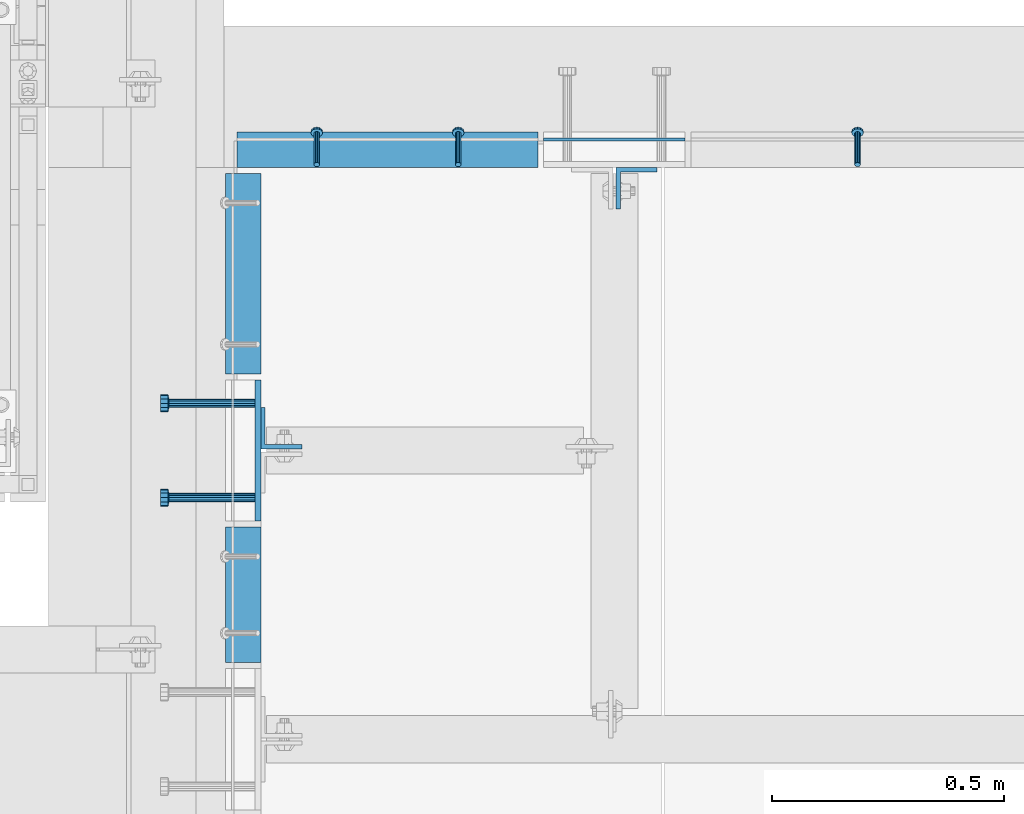
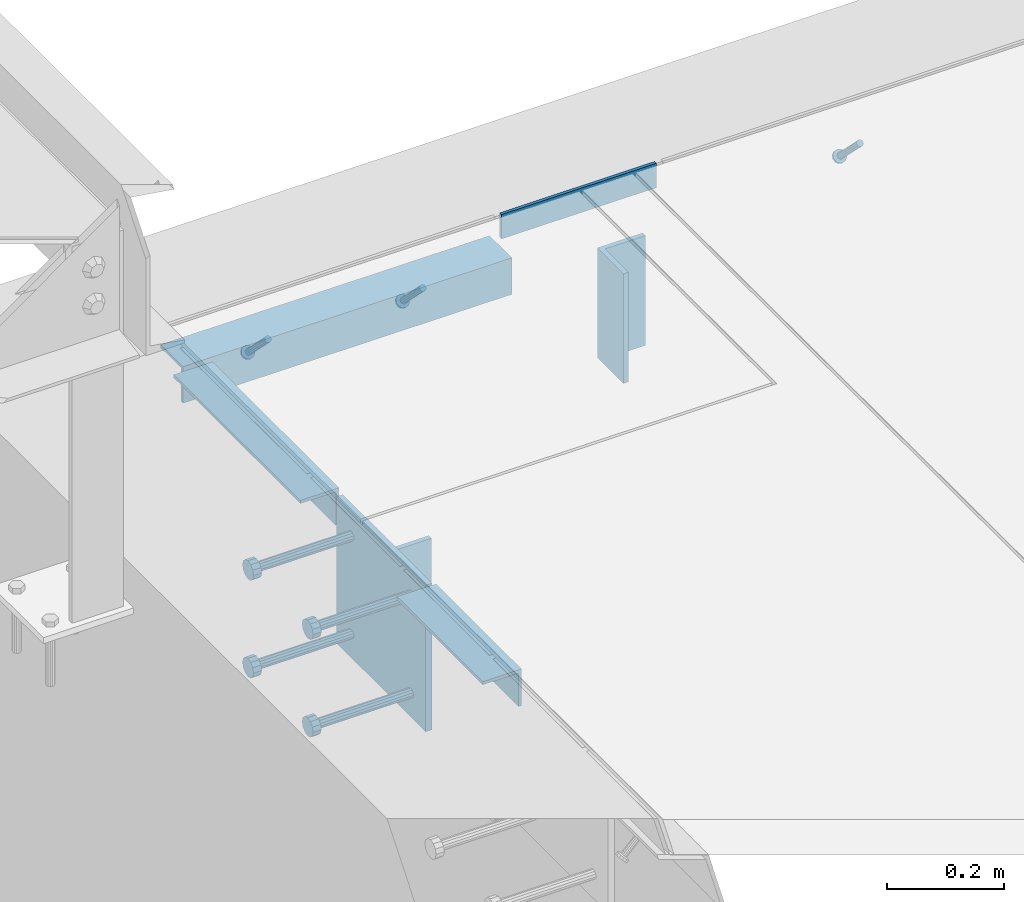
# One storey, part 2078 of 3843: 11 beams, 3 members, 8 elements without a shape of their own.
"""IFC2X3 building model written with IfcOpenShell, lengths in millimetres."""

from ifc_helpers import new_model, si_unit, frame, origin_with_axes, place, context, subcontext, project, spatial, faceted_brep, material, type_object, element, aggregate, save


model = new_model("IFC2X3")

# Units and contexts
model_context = context("Model", 3, precision=1e-05, world=origin_with_axes())
body_context = subcontext(model_context, "Body", "Model", "MODEL_VIEW")
ifc_project = project(units=[si_unit("LENGTHUNIT", "METRE", prefix="MILLI"), si_unit("AREAUNIT", "SQUARE_METRE"), si_unit("VOLUMEUNIT", "CUBIC_METRE"), si_unit("MASSUNIT", "GRAM", prefix="KILO"), si_unit("TIMEUNIT", "SECOND"), si_unit("PLANEANGLEUNIT", "RADIAN"), si_unit("SOLIDANGLEUNIT", "STERADIAN"), si_unit("THERMODYNAMICTEMPERATUREUNIT", "DEGREE_CELSIUS"), si_unit("LUMINOUSINTENSITYUNIT", "LUMEN")], contexts=[model_context])

# Site, building, storey
site_placement = place(None, origin_with_axes())
site = spatial("IfcSite", under=ifc_project, at=site_placement, CompositionType="ELEMENT")
building_placement = place(site_placement, origin_with_axes())
building = spatial("IfcBuilding", under=site, at=building_placement, Name="Undefined", CompositionType="ELEMENT")
storey_placement = place(building_placement, origin_with_axes())
storey = spatial("IfcBuildingStorey", under=building, at=storey_placement, Name="Undefined", CompositionType="ELEMENT", Elevation=0.0)

# Assembly, beam
assembly_1_placement = place(storey_placement, origin_with_axes())
assembly_1 = element("IfcElementAssembly", 1, at=assembly_1_placement, inside=storey, Name="EMBED PLATE", AssemblyPlace="NOTDEFINED", PredefinedType="RIGID_FRAME")
ifc_material_1 = material(Name="STEEL/A36")
beam_type_1 = type_object("IfcBeamType", PredefinedType="NOTDEFINED")
beam_1_placement = place(assembly_1_placement, frame((56749.95, 18751.55, 30454.6), z_axis=(0.0, 0.0, 1.0), x_axis=(1.0, 0.0, 0.0)))
beam_1 = element("IfcBeam", 2, at=beam_1_placement, type_object=beam_type_1, material=ifc_material_1, Name="PLATE", context=body_context, shape_type="Brep", body=[
    faceted_brep([(0.0, 3.17499999999927, -25.4000000000015), (0.0, 3.17499999999927, 25.4000000000015), (304.800000000003, 3.17500000000291, 25.4000000000015), (304.800000000003, 3.17500000000291, -25.4000000000015), (0.0, -3.17499999999927, 25.4000000000015), (304.800000000003, -3.17500000000291, 25.4000000000015), (0.0, -3.17499999999927, -25.4000000000015), (304.800000000003, -3.17500000000291, -25.4000000000015)], [[[0, 1, 2, 3]], [[1, 4, 5, 2]], [[4, 6, 7, 5]], [[6, 0, 3, 7]], [[5, 7, 3, 2]], [[6, 4, 1, 0]]]),
])
aggregate(assembly_1, [beam_1])

# Assembly, member
assembly_2_placement = place(storey_placement, origin_with_axes())
assembly_2 = element("IfcElementAssembly", 3, at=assembly_2_placement, inside=storey, Name="ANGLE", AssemblyPlace="NOTDEFINED", PredefinedType="RIGID_FRAME")
ifc_material_2 = material(Name="STEEL/A108")
member_type = type_object("IfcMemberType", PredefinedType="NOTDEFINED")
member_1_placement = place(assembly_2_placement, frame((57426.2248493546, 18697.5750781257, 30422.8500030518), z_axis=(-1.0, 0.0, 0.0), x_axis=(5.70000238222118e-08, 0.707106781186546, -0.707106781186546)))
member_1 = element("IfcMember", 4, at=member_1_placement, type_object=member_type, material=ifc_material_2, Name="HEADED STUD ANCHOR", context=body_context, shape_type="Brep", body=[
    faceted_brep([(7.27595761418343e-12, -3.18000006675175, 5.5), (0.0, -5.49999999998363, 3.1800000667572), (94.4879985803855, -5.50000000011278, 3.1800000667572), (94.4879985803782, -3.18000006687362, 5.5), (0.0, -6.3499999046162, 0.0), (94.4879985803855, -6.34999990474535, 0.0), (0.0, -5.49999999998363, -3.1800000667572), (94.4879985803855, -5.50000000011278, -3.1800000667572), (7.27595761418343e-12, -3.18000006675175, -5.5), (94.4879985803782, -3.18000006687362, -5.5), (7.27595761418343e-12, -1.81898940354586e-12, -6.34999990463257), (94.4879985803782, -1.20053300634027e-10, -6.34999990463257), (0.0, 3.18000006675175, -5.5), (94.4879985803709, 3.18000006663351, -5.5), (7.27595761418343e-12, 5.49999999998363, -3.1800000667572), (94.4879985803709, 5.49999999987267, -3.1800000667572), (7.27595761418343e-12, 6.3499999046162, 0.0), (94.4879985803673, 6.34999990450706, 0.0), (7.27595761418343e-12, 5.49999999998363, 3.1800000667572), (94.4879985803709, 5.49999999987267, 3.1800000667572), (0.0, 3.18000006675175, 5.5), (94.4879985803709, 3.18000006663351, 5.5), (7.27595761418343e-12, -1.81898940354586e-12, 6.34999990463257), (94.4879985803782, -1.20053300634027e-10, 6.34999990463257), (96.5199985498621, -10.9899997712273, 6.34999990463257), (96.5199985498548, -6.34000015270249, 10.9899997711182), (96.5199985498621, -12.6999998093743, 0.0), (96.5199985498621, -10.9899997712273, -6.34999990463257), (96.5199985498548, -6.34000015270249, -10.9899997711182), (96.5199985498475, -1.21872290037572e-10, -12.6899995803833), (96.5199985498402, 6.34000015245874, -10.9899997711182), (96.519998549833, 10.9899997709817, -6.34999990463257), (96.519998549833, 12.6999998091305, 0.0), (96.519998549833, 10.9899997709817, 6.34999990463257), (96.5199985498402, 6.34000015245874, 10.9899997711182), (96.5199985498475, -1.21872290037572e-10, 12.6899995803833), (101.599998473539, -10.9899997712328, 6.34999990463257), (101.599998473532, -6.34000015270976, 10.9899997711182), (101.599998473539, -12.6999998093797, 0.0), (101.599998473539, -10.9899997712328, -6.34999990463257), (101.599998473532, -6.34000015270976, -10.9899997711182), (101.599998473524, -1.29148247651756e-10, -12.6899995803833), (101.599998473517, 6.34000015245329, -10.9899997711182), (101.59999847351, 10.9899997709763, -6.34999990463257), (101.599998473503, 12.6999998091196, 0.0), (101.59999847351, 10.9899997709763, 6.34999990463257), (101.599998473517, 6.34000015245329, 10.9899997711182), (101.599998473524, -1.29148247651756e-10, 12.6899995803833)], [[[0, 1, 2, 3]], [[1, 4, 5, 2]], [[4, 6, 7, 5]], [[6, 8, 9, 7]], [[8, 10, 11, 9]], [[10, 12, 13, 11]], [[12, 14, 15, 13]], [[14, 16, 17, 15]], [[16, 18, 19, 17]], [[18, 20, 21, 19]], [[20, 22, 23, 21]], [[22, 0, 3, 23]], [[22, 20, 18, 16, 14, 12, 10, 8, 6, 4, 1, 0]], [[3, 2, 24, 25]], [[2, 5, 26, 24]], [[5, 7, 27, 26]], [[7, 9, 28, 27]], [[9, 11, 29, 28]], [[11, 13, 30, 29]], [[13, 15, 31, 30]], [[15, 17, 32, 31]], [[17, 19, 33, 32]], [[19, 21, 34, 33]], [[21, 23, 35, 34]], [[23, 3, 25, 35]], [[25, 24, 36, 37]], [[24, 26, 38, 36]], [[26, 27, 39, 38]], [[27, 28, 40, 39]], [[28, 29, 41, 40]], [[29, 30, 42, 41]], [[30, 31, 43, 42]], [[31, 32, 44, 43]], [[32, 33, 45, 44]], [[33, 34, 46, 45]], [[34, 35, 47, 46]], [[35, 25, 37, 47]], [[38, 39, 40, 41, 42, 43, 44, 45, 46, 47, 37, 36]]]),
])
aggregate(assembly_2, [member_1])

# Assembly, members
assembly_3_placement = place(storey_placement, origin_with_axes())
assembly_3 = element("IfcElementAssembly", 5, at=assembly_3_placement, inside=storey, Name="ANGLE", AssemblyPlace="NOTDEFINED", PredefinedType="RIGID_FRAME")
member_2_placement = place(assembly_3_placement, frame((56565.799910662, 18697.574900916, 30422.8500030518), z_axis=(-1.0, 0.0, 0.0), x_axis=(5.70000238222118e-08, 0.707106781186546, -0.707106781186546)))
member_2 = element("IfcMember", 6, at=member_2_placement, type_object=member_type, material=ifc_material_2, Name="HEADED STUD ANCHOR", context=body_context, shape_type="Brep", body=[
    faceted_brep([(7.27595761418343e-12, -3.18000006675175, 5.5), (0.0, -5.49999999998363, 3.1800000667572), (94.4879985803855, -5.50000000011278, 3.1800000667572), (94.4879985803782, -3.18000006687362, 5.5), (0.0, -6.3499999046162, 0.0), (94.4879985803855, -6.34999990474535, 0.0), (0.0, -5.49999999998363, -3.1800000667572), (94.4879985803855, -5.50000000011278, -3.1800000667572), (7.27595761418343e-12, -3.18000006675175, -5.5), (94.4879985803782, -3.18000006687362, -5.5), (7.27595761418343e-12, -1.81898940354586e-12, -6.34999990463257), (94.4879985803782, -1.20053300634027e-10, -6.34999990463257), (0.0, 3.18000006675175, -5.5), (94.4879985803709, 3.18000006663351, -5.5), (7.27595761418343e-12, 5.49999999998363, -3.1800000667572), (94.4879985803709, 5.49999999987267, -3.1800000667572), (7.27595761418343e-12, 6.3499999046162, 0.0), (94.4879985803673, 6.34999990450706, 0.0), (7.27595761418343e-12, 5.49999999998363, 3.1800000667572), (94.4879985803709, 5.49999999987267, 3.1800000667572), (0.0, 3.18000006675175, 5.5), (94.4879985803709, 3.18000006663351, 5.5), (7.27595761418343e-12, -1.81898940354586e-12, 6.34999990463257), (94.4879985803782, -1.20053300634027e-10, 6.34999990463257), (96.5199985498621, -10.9899997712273, 6.34999990463257), (96.5199985498548, -6.34000015270249, 10.9899997711182), (96.5199985498621, -12.6999998093743, 0.0), (96.5199985498621, -10.9899997712273, -6.34999990463257), (96.5199985498548, -6.34000015270249, -10.9899997711182), (96.5199985498475, -1.21872290037572e-10, -12.6899995803833), (96.5199985498402, 6.34000015245874, -10.9899997711182), (96.519998549833, 10.9899997709817, -6.34999990463257), (96.519998549833, 12.6999998091305, 0.0), (96.519998549833, 10.9899997709817, 6.34999990463257), (96.5199985498402, 6.34000015245874, 10.9899997711182), (96.5199985498475, -1.21872290037572e-10, 12.6899995803833), (101.599998473539, -10.9899997712328, 6.34999990463257), (101.599998473532, -6.34000015270976, 10.9899997711182), (101.599998473539, -12.6999998093797, 0.0), (101.599998473539, -10.9899997712328, -6.34999990463257), (101.599998473532, -6.34000015270976, -10.9899997711182), (101.599998473524, -1.29148247651756e-10, -12.6899995803833), (101.599998473517, 6.34000015245329, -10.9899997711182), (101.59999847351, 10.9899997709763, -6.34999990463257), (101.599998473503, 12.6999998091196, 0.0), (101.59999847351, 10.9899997709763, 6.34999990463257), (101.599998473517, 6.34000015245329, 10.9899997711182), (101.599998473524, -1.29148247651756e-10, 12.6899995803833)], [[[0, 1, 2, 3]], [[1, 4, 5, 2]], [[4, 6, 7, 5]], [[6, 8, 9, 7]], [[8, 10, 11, 9]], [[10, 12, 13, 11]], [[12, 14, 15, 13]], [[14, 16, 17, 15]], [[16, 18, 19, 17]], [[18, 20, 21, 19]], [[20, 22, 23, 21]], [[22, 0, 3, 23]], [[22, 20, 18, 16, 14, 12, 10, 8, 6, 4, 1, 0]], [[3, 2, 24, 25]], [[2, 5, 26, 24]], [[5, 7, 27, 26]], [[7, 9, 28, 27]], [[9, 11, 29, 28]], [[11, 13, 30, 29]], [[13, 15, 31, 30]], [[15, 17, 32, 31]], [[17, 19, 33, 32]], [[19, 21, 34, 33]], [[21, 23, 35, 34]], [[23, 3, 25, 35]], [[25, 24, 36, 37]], [[24, 26, 38, 36]], [[26, 27, 39, 38]], [[27, 28, 40, 39]], [[28, 29, 41, 40]], [[29, 30, 42, 41]], [[30, 31, 43, 42]], [[31, 32, 44, 43]], [[32, 33, 45, 44]], [[33, 34, 46, 45]], [[34, 35, 47, 46]], [[35, 25, 37, 47]], [[38, 39, 40, 41, 42, 43, 44, 45, 46, 47, 37, 36]]]),
])
member_3_placement = place(assembly_3_placement, frame((56260.999910662, 18697.574900916, 30422.8500030518), z_axis=(-1.0, 0.0, 0.0), x_axis=(5.70000238222118e-08, 0.707106781186546, -0.707106781186546)))
member_3 = element("IfcMember", 7, at=member_3_placement, type_object=member_type, material=ifc_material_2, Name="HEADED STUD ANCHOR", context=body_context, shape_type="Brep", body=[
    faceted_brep([(7.27595761418343e-12, -3.18000006675175, 5.5), (0.0, -5.49999999998363, 3.1800000667572), (94.4879985803855, -5.50000000011278, 3.1800000667572), (94.4879985803782, -3.18000006687362, 5.5), (0.0, -6.3499999046162, 0.0), (94.4879985803855, -6.34999990474535, 0.0), (0.0, -5.49999999998363, -3.1800000667572), (94.4879985803855, -5.50000000011278, -3.1800000667572), (7.27595761418343e-12, -3.18000006675175, -5.5), (94.4879985803782, -3.18000006687362, -5.5), (7.27595761418343e-12, -1.81898940354586e-12, -6.34999990463257), (94.4879985803782, -1.20053300634027e-10, -6.34999990463257), (0.0, 3.18000006675175, -5.5), (94.4879985803709, 3.18000006663351, -5.5), (7.27595761418343e-12, 5.49999999998363, -3.1800000667572), (94.4879985803709, 5.49999999987267, -3.1800000667572), (7.27595761418343e-12, 6.3499999046162, 0.0), (94.4879985803673, 6.34999990450706, 0.0), (7.27595761418343e-12, 5.49999999998363, 3.1800000667572), (94.4879985803709, 5.49999999987267, 3.1800000667572), (0.0, 3.18000006675175, 5.5), (94.4879985803709, 3.18000006663351, 5.5), (7.27595761418343e-12, -1.81898940354586e-12, 6.34999990463257), (94.4879985803782, -1.20053300634027e-10, 6.34999990463257), (96.5199985498621, -10.9899997712273, 6.34999990463257), (96.5199985498548, -6.34000015270249, 10.9899997711182), (96.5199985498621, -12.6999998093743, 0.0), (96.5199985498621, -10.9899997712273, -6.34999990463257), (96.5199985498548, -6.34000015270249, -10.9899997711182), (96.5199985498475, -1.21872290037572e-10, -12.6899995803833), (96.5199985498402, 6.34000015245874, -10.9899997711182), (96.519998549833, 10.9899997709817, -6.34999990463257), (96.519998549833, 12.6999998091305, 0.0), (96.519998549833, 10.9899997709817, 6.34999990463257), (96.5199985498402, 6.34000015245874, 10.9899997711182), (96.5199985498475, -1.21872290037572e-10, 12.6899995803833), (101.599998473539, -10.9899997712328, 6.34999990463257), (101.599998473532, -6.34000015270976, 10.9899997711182), (101.599998473539, -12.6999998093797, 0.0), (101.599998473539, -10.9899997712328, -6.34999990463257), (101.599998473532, -6.34000015270976, -10.9899997711182), (101.599998473524, -1.29148247651756e-10, -12.6899995803833), (101.599998473517, 6.34000015245329, -10.9899997711182), (101.59999847351, 10.9899997709763, -6.34999990463257), (101.599998473503, 12.6999998091196, 0.0), (101.59999847351, 10.9899997709763, 6.34999990463257), (101.599998473517, 6.34000015245329, 10.9899997711182), (101.599998473524, -1.29148247651756e-10, 12.6899995803833)], [[[0, 1, 2, 3]], [[1, 4, 5, 2]], [[4, 6, 7, 5]], [[6, 8, 9, 7]], [[8, 10, 11, 9]], [[10, 12, 13, 11]], [[12, 14, 15, 13]], [[14, 16, 17, 15]], [[16, 18, 19, 17]], [[18, 20, 21, 19]], [[20, 22, 23, 21]], [[22, 0, 3, 23]], [[22, 20, 18, 16, 14, 12, 10, 8, 6, 4, 1, 0]], [[3, 2, 24, 25]], [[2, 5, 26, 24]], [[5, 7, 27, 26]], [[7, 9, 28, 27]], [[9, 11, 29, 28]], [[11, 13, 30, 29]], [[13, 15, 31, 30]], [[15, 17, 32, 31]], [[17, 19, 33, 32]], [[19, 21, 34, 33]], [[21, 23, 35, 34]], [[23, 3, 25, 35]], [[25, 24, 36, 37]], [[24, 26, 38, 36]], [[26, 27, 39, 38]], [[27, 28, 40, 39]], [[28, 29, 41, 40]], [[29, 30, 42, 41]], [[30, 31, 43, 42]], [[31, 32, 44, 43]], [[32, 33, 45, 44]], [[33, 34, 46, 45]], [[34, 35, 47, 46]], [[35, 25, 37, 47]], [[38, 39, 40, 41, 42, 43, 44, 45, 46, 47, 37, 36]]]),
])

# Assembly, beam
assembly_4_placement = place(storey_placement, origin_with_axes())
assembly_4 = element("IfcElementAssembly", 8, at=assembly_4_placement, inside=storey, Name="EMBED PLATE", AssemblyPlace="NOTDEFINED", PredefinedType="RIGID_FRAME")
beam_type_2 = type_object("IfcBeamType", PredefinedType="NOTDEFINED")
beam_2_placement = place(assembly_4_placement, frame((56134.0000030518, 18081.625, 30422.85), z_axis=(0.0, 1.0, 0.0), x_axis=(0.0, 0.0, -1.0)))
beam_2 = element("IfcBeam", 9, at=beam_2_placement, type_object=beam_type_2, material=ifc_material_1, Name="EMBED PLATE", context=body_context, shape_type="Brep", body=[
    faceted_brep([(-1.0550138540566e-10, 6.34999999999854, -152.400000000664), (1.0550138540566e-10, 6.34999999999854, 152.400000000656), (304.799999999999, 6.34999999999854, 152.400000000001), (304.799999999999, 6.34999999999854, -152.400000000001), (1.0550138540566e-10, -6.34999999999854, 152.400000000656), (304.799999999999, -6.34999999999854, 152.400000000001), (-1.0550138540566e-10, -6.34999999999854, -152.400000000664), (304.799999999999, -6.34999999999854, -152.400000000001)], [[[0, 1, 2, 3]], [[1, 4, 5, 2]], [[4, 6, 7, 5]], [[6, 0, 3, 7]], [[5, 7, 3, 2]], [[6, 4, 1, 0]]]),
])

assembly_5_placement = place(storey_placement, origin_with_axes())
assembly_5 = element("IfcElementAssembly", 10, at=assembly_5_placement, inside=storey, Name="ANGLE", AssemblyPlace="NOTDEFINED", PredefinedType="RIGID_FRAME")
beam_type_3 = type_object("IfcBeamType", Name="L3X3X1/4", PredefinedType="NOTDEFINED")
beam_3_placement = place(assembly_5_placement, frame((56102.2500000941, 17624.4250731787, 30391.1000045777), z_axis=(0.0, 0.0, -1.0), x_axis=(0.0, 1.0, 0.0)))
beam_3 = element("IfcBeam", 11, at=beam_3_placement, type_object=beam_type_3, material=ifc_material_1, Name="ANGLE", ObjectType="L3X3X1/4", context=body_context, shape_type="Brep", body=[
    faceted_brep([(0.0, 38.0999999999985, -38.0999999999985), (0.0, 38.0999999999985, 38.0999999999985), (292.099926759005, 38.0999999991764, 38.0999999999985), (292.099926759005, 38.0999999991764, -38.0999999999985), (0.0, 31.75, 38.0999999999985), (292.099926759009, 31.7499999991778, 38.0999999999985), (0.0, 31.75, -31.75), (292.099926759009, 31.7499999991778, -31.75), (0.0, -38.0999999999985, -31.75), (292.099926759067, -38.1000000008207, -31.75), (0.0, -38.0999999999985, -38.0999999999985), (292.099926759067, -38.1000000008207, -38.0999999999985)], [[[0, 1, 2, 3]], [[1, 4, 5, 2]], [[4, 6, 7, 5]], [[6, 8, 9, 7]], [[8, 10, 11, 9]], [[10, 0, 3, 11]], [[5, 7, 9, 11, 3, 2]], [[10, 8, 6, 4, 1, 0]]]),
])
aggregate(assembly_5, [beam_3])

assembly_6_placement = place(storey_placement, origin_with_axes())
assembly_6 = element("IfcElementAssembly", 12, at=assembly_6_placement, inside=storey, Name="ANGLE", AssemblyPlace="NOTDEFINED", PredefinedType="RIGID_FRAME")
beam_4_placement = place(assembly_6_placement, frame((56102.2500000941, 18246.7250002667, 30391.1000045777), z_axis=(0.0, 0.0, -1.0), x_axis=(0.0, 1.0, 0.0)))
beam_4 = element("IfcBeam", 13, at=beam_4_placement, type_object=beam_type_3, material=ifc_material_1, Name="ANGLE", ObjectType="L3X3X1/4", context=body_context, shape_type="Brep", body=[
    faceted_brep([(0.0, 38.0999999999985, -38.0999999999985), (0.0, 38.0999999999985, 38.0999999999985), (431.800000000025, 38.0999999997803, 38.0999999999985), (431.800000000025, 38.0999999997803, -38.0999999999985), (0.0, 31.75, 38.0999999999985), (431.800000000021, 31.7499999997817, 38.0999999999985), (0.0, 31.75, -31.75), (431.800000000021, 31.7499999997817, -31.75), (0.0, -38.0999999999985, -31.75), (431.799999999981, -38.1000000002241, -31.75), (0.0, -38.0999999999985, -38.0999999999985), (431.799999999981, -38.1000000002241, -38.0999999999985)], [[[0, 1, 2, 3]], [[1, 4, 5, 2]], [[4, 6, 7, 5]], [[6, 8, 9, 7]], [[8, 10, 11, 9]], [[10, 0, 3, 11]], [[5, 7, 9, 11, 3, 2]], [[10, 8, 6, 4, 1, 0]]]),
])
aggregate(assembly_6, [beam_4])

# Beam
beam_5_placement = place(assembly_3_placement, frame((56089.5498712958, 18729.324900916, 30391.1000030518), z_axis=(0.0, 0.0, -1.0), x_axis=(1.0, 0.0, 0.0)))
beam_5 = element("IfcBeam", 14, at=beam_5_placement, type_object=beam_type_3, material=ifc_material_1, Name="ANGLE", ObjectType="L3X3X1/4", context=body_context, shape_type="Brep", body=[
    faceted_brep([(0.0, 38.0999999999985, -38.0999999999985), (0.0, 38.0999999999985, 38.0999999999985), (647.700078732363, 38.0999999999985, 38.0999999999985), (647.700078732363, 38.0999999999985, -38.0999999999985), (0.0, 31.75, 38.0999999999985), (647.700078732363, 31.75, 38.0999999999985), (0.0, 31.75, -31.75), (647.700078732363, 31.75, -31.75), (0.0, -38.0999999999985, -31.75), (647.700078732363, -38.0999999999985, -31.75), (0.0, -38.0999999999985, -38.0999999999985), (647.700078732363, -38.0999999999985, -38.0999999999985)], [[[0, 1, 2, 3]], [[1, 4, 5, 2]], [[4, 6, 7, 5]], [[6, 8, 9, 7]], [[8, 10, 11, 9]], [[10, 0, 3, 11]], [[5, 7, 9, 11, 3, 2]], [[10, 8, 6, 4, 1, 0]]]),
])

aggregate(assembly_3, [member_2, member_3, beam_5])

# Assembly, beam
assembly_7_placement = place(storey_placement, origin_with_axes())
assembly_7 = element("IfcElementAssembly", 15, at=assembly_7_placement, inside=storey, Name="BEAM", AssemblyPlace="NOTDEFINED", PredefinedType="RIGID_FRAME")
beam_type_4 = type_object("IfcBeamType", Name="L3-1/2X3-1/2X3/8", PredefinedType="NOTDEFINED")
beam_6_placement = place(assembly_7_placement, frame((56184.8000030518, 18129.25, 30391.1), z_axis=(0.0, 1.0, 0.0), x_axis=(0.0, 0.0, -1.0)))
beam_6 = element("IfcBeam", 16, at=beam_6_placement, type_object=beam_type_4, material=ifc_material_1, Name="ANGLE", ObjectType="L3-1/2X3-1/2X3/8", context=body_context, shape_type="Brep", body=[
    faceted_brep([(-3.63797880709171e-12, 44.4499999999971, -44.4500000000007), (-3.63797880709171e-12, 44.4499999999971, 44.4500000000007), (228.600000000006, 44.4499999999971, 44.4500000000007), (228.600000000006, 44.4499999999971, -44.4500000000007), (0.0, 34.9250000000029, 44.4500000000007), (228.600000000006, 34.9250000000029, 44.4500000000007), (0.0, 34.9250000000029, -34.9250000000029), (228.600000000006, 34.9250000000029, -34.9249999999993), (0.0, -44.4499999999971, -34.9249999999993), (228.600000000006, -44.4499999999971, -34.9249999999993), (3.63797880709171e-12, -44.4499999999971, -44.4500000000007), (228.600000000006, -44.4499999999971, -44.4500000000007)], [[[0, 1, 2, 3]], [[1, 4, 5, 2]], [[4, 6, 7, 5]], [[6, 8, 9, 7]], [[8, 10, 11, 9]], [[10, 0, 3, 11]], [[5, 7, 9, 11, 3, 2]], [[10, 8, 6, 4, 1, 0]]]),
])
aggregate(assembly_7, [beam_6])

assembly_8_placement = place(storey_placement, origin_with_axes())
assembly_8 = element("IfcElementAssembly", 17, at=assembly_8_placement, inside=storey, Name="BEAM", AssemblyPlace="NOTDEFINED", PredefinedType="RIGID_FRAME")
beam_7_placement = place(assembly_8_placement, frame((56949.975, 18646.775, 30391.1), z_axis=(1.0, 0.0, 0.0), x_axis=(0.0, 0.0, -1.0)))
beam_7 = element("IfcBeam", 18, at=beam_7_placement, type_object=beam_type_4, material=ifc_material_1, Name="ANGLE", ObjectType="L3-1/2X3-1/2X3/8", context=body_context, shape_type="Brep", body=[
    faceted_brep([(-3.63797880709171e-12, 44.4499999999971, -44.4500000000007), (-3.63797880709171e-12, 44.4499999999971, 44.4500000000007), (228.600000000006, 44.4499999999971, 44.4500000000007), (228.600000000006, 44.4499999999971, -44.4500000000007), (0.0, 34.9250000000029, 44.4500000000007), (228.600000000006, 34.9250000000029, 44.4500000000007), (0.0, 34.9250000000029, -34.9250000000029), (228.600000000006, 34.9250000000029, -34.9249999999993), (0.0, -44.4499999999971, -34.9249999999993), (228.600000000006, -44.4499999999971, -34.9249999999993), (3.63797880709171e-12, -44.4499999999971, -44.4500000000007), (228.600000000006, -44.4499999999971, -44.4500000000007)], [[[0, 1, 2, 3]], [[1, 4, 5, 2]], [[4, 6, 7, 5]], [[6, 8, 9, 7]], [[8, 10, 11, 9]], [[10, 0, 3, 11]], [[5, 7, 9, 11, 3, 2]], [[10, 8, 6, 4, 1, 0]]]),
])
aggregate(assembly_8, [beam_7])

# Beam
beam_type_5 = type_object("IfcBeamType", PredefinedType="NOTDEFINED")
beam_8_placement = place(assembly_4_placement, frame((56127.6500030518, 17980.025, 30372.05), z_axis=(0.0, -1.0, 0.0), x_axis=(-1.0, 0.0, 0.0)))
beam_8 = element("IfcBeam", 19, at=beam_8_placement, type_object=beam_type_5, material=ifc_material_2, Name="HEADED STUD ANCHOR", context=body_context, shape_type="Brep", body=[
    faceted_brep([(0.0, -9.52000045776367, 0.0), (0.0, -8.25, -4.76000022888184), (184.912000000004, -8.25, -4.76000022888184), (184.912000000004, -9.52000045776367, 0.0), (0.0, -4.76000022888184, -8.25), (184.912000000004, -4.76000022888184, -8.25), (0.0, 0.0, -9.52000045776367), (184.912000000004, 0.0, -9.52000045776367), (0.0, 4.76000022888184, -8.25), (184.912000000004, 4.76000022888184, -8.25), (0.0, 8.25, -4.76000022888184), (184.912000000004, 8.25, -4.76000022888184), (0.0, 9.52000045776367, 0.0), (184.912000000004, 9.52000045776367, 0.0), (0.0, 8.25, 4.76000022888184), (184.912000000004, 8.25, 4.76000022888184), (0.0, 4.76000022888184, 8.25), (184.912000000004, 4.76000022888184, 8.25), (0.0, 0.0, 9.52000045776367), (184.912000000004, 0.0, 9.52000045776367), (0.0, -4.76000022888184, 8.25), (184.912000000004, -4.76000022888184, 8.25), (0.0, -8.25, 4.76000022888184), (184.912000000004, -8.25, 4.76000022888184), (186.944000000003, -16.5, -9.52000045776367), (186.944000000003, -19.0499992370605, 0.0), (186.944000000003, -9.52000045776367, -16.5), (186.944000000003, 0.0, -19.0499992370605), (186.944000000003, 9.52000045776367, -16.5), (186.944000000003, 16.5, -9.52000045776367), (186.944000000003, 19.0499992370605, 0.0), (186.944000000003, 16.5, 9.52000045776367), (186.944000000003, 9.52000045776367, 16.5), (186.944000000003, 0.0, 19.0499992370605), (186.944000000003, -9.52000045776367, 16.5), (186.944000000003, -16.5, 9.52000045776367), (203.199999999997, -16.5, -9.52000045776367), (203.199999999997, -19.0499992370605, 0.0), (203.199999999997, -9.52000045776367, -16.5), (203.199999999997, 0.0, -19.0499992370605), (203.199999999997, 9.52000045776367, -16.5), (203.199999999997, 16.5, -9.52000045776367), (203.199999999997, 19.0499992370605, 0.0), (203.199999999997, 16.5, 9.52000045776367), (203.199999999997, 9.52000045776367, 16.5), (203.199999999997, 0.0, 19.0499992370605), (203.199999999997, -9.52000045776367, 16.5), (203.199999999997, -16.5, 9.52000045776367)], [[[0, 1, 2, 3]], [[1, 4, 5, 2]], [[4, 6, 7, 5]], [[6, 8, 9, 7]], [[8, 10, 11, 9]], [[10, 12, 13, 11]], [[12, 14, 15, 13]], [[14, 16, 17, 15]], [[16, 18, 19, 17]], [[18, 20, 21, 19]], [[20, 22, 23, 21]], [[22, 0, 3, 23]], [[22, 20, 18, 16, 14, 12, 10, 8, 6, 4, 1, 0]], [[3, 2, 24, 25]], [[2, 5, 26, 24]], [[5, 7, 27, 26]], [[7, 9, 28, 27]], [[9, 11, 29, 28]], [[11, 13, 30, 29]], [[13, 15, 31, 30]], [[15, 17, 32, 31]], [[17, 19, 33, 32]], [[19, 21, 34, 33]], [[21, 23, 35, 34]], [[23, 3, 25, 35]], [[25, 24, 36, 37]], [[24, 26, 38, 36]], [[26, 27, 39, 38]], [[27, 28, 40, 39]], [[28, 29, 41, 40]], [[29, 30, 42, 41]], [[30, 31, 43, 42]], [[31, 32, 44, 43]], [[32, 33, 45, 44]], [[33, 34, 46, 45]], [[34, 35, 47, 46]], [[35, 25, 37, 47]], [[38, 39, 40, 41, 42, 43, 44, 45, 46, 47, 37, 36]]]),
])

beam_9_placement = place(assembly_4_placement, frame((56127.6500030518, 17980.025, 30168.85), z_axis=(0.0, -1.0, 0.0), x_axis=(-1.0, 0.0, 0.0)))
beam_9 = element("IfcBeam", 20, at=beam_9_placement, type_object=beam_type_5, material=ifc_material_2, Name="HEADED STUD ANCHOR", context=body_context, shape_type="Brep", body=[
    faceted_brep([(0.0, -9.52000045776367, 0.0), (0.0, -8.25, -4.76000022888184), (184.912000000004, -8.25, -4.76000022888184), (184.912000000004, -9.52000045776367, 0.0), (0.0, -4.76000022888184, -8.25), (184.912000000004, -4.76000022888184, -8.25), (0.0, 0.0, -9.52000045776367), (184.912000000004, 0.0, -9.52000045776367), (0.0, 4.76000022888184, -8.25), (184.912000000004, 4.76000022888184, -8.25), (0.0, 8.25, -4.76000022888184), (184.912000000004, 8.25, -4.76000022888184), (0.0, 9.52000045776367, 0.0), (184.912000000004, 9.52000045776367, 0.0), (0.0, 8.25, 4.76000022888184), (184.912000000004, 8.25, 4.76000022888184), (0.0, 4.76000022888184, 8.25), (184.912000000004, 4.76000022888184, 8.25), (0.0, 0.0, 9.52000045776367), (184.912000000004, 0.0, 9.52000045776367), (0.0, -4.76000022888184, 8.25), (184.912000000004, -4.76000022888184, 8.25), (0.0, -8.25, 4.76000022888184), (184.912000000004, -8.25, 4.76000022888184), (186.944000000003, -16.5, -9.52000045776367), (186.944000000003, -19.0499992370605, 0.0), (186.944000000003, -9.52000045776367, -16.5), (186.944000000003, 0.0, -19.0499992370605), (186.944000000003, 9.52000045776367, -16.5), (186.944000000003, 16.5, -9.52000045776367), (186.944000000003, 19.0499992370605, 0.0), (186.944000000003, 16.5, 9.52000045776367), (186.944000000003, 9.52000045776367, 16.5), (186.944000000003, 0.0, 19.0499992370605), (186.944000000003, -9.52000045776367, 16.5), (186.944000000003, -16.5, 9.52000045776367), (203.199999999997, -16.5, -9.52000045776367), (203.199999999997, -19.0499992370605, 0.0), (203.199999999997, -9.52000045776367, -16.5), (203.199999999997, 0.0, -19.0499992370605), (203.199999999997, 9.52000045776367, -16.5), (203.199999999997, 16.5, -9.52000045776367), (203.199999999997, 19.0499992370605, 0.0), (203.199999999997, 16.5, 9.52000045776367), (203.199999999997, 9.52000045776367, 16.5), (203.199999999997, 0.0, 19.0499992370605), (203.199999999997, -9.52000045776367, 16.5), (203.199999999997, -16.5, 9.52000045776367)], [[[0, 1, 2, 3]], [[1, 4, 5, 2]], [[4, 6, 7, 5]], [[6, 8, 9, 7]], [[8, 10, 11, 9]], [[10, 12, 13, 11]], [[12, 14, 15, 13]], [[14, 16, 17, 15]], [[16, 18, 19, 17]], [[18, 20, 21, 19]], [[20, 22, 23, 21]], [[22, 0, 3, 23]], [[22, 20, 18, 16, 14, 12, 10, 8, 6, 4, 1, 0]], [[3, 2, 24, 25]], [[2, 5, 26, 24]], [[5, 7, 27, 26]], [[7, 9, 28, 27]], [[9, 11, 29, 28]], [[11, 13, 30, 29]], [[13, 15, 31, 30]], [[15, 17, 32, 31]], [[17, 19, 33, 32]], [[19, 21, 34, 33]], [[21, 23, 35, 34]], [[23, 3, 25, 35]], [[25, 24, 36, 37]], [[24, 26, 38, 36]], [[26, 27, 39, 38]], [[27, 28, 40, 39]], [[28, 29, 41, 40]], [[29, 30, 42, 41]], [[30, 31, 43, 42]], [[31, 32, 44, 43]], [[32, 33, 45, 44]], [[33, 34, 46, 45]], [[34, 35, 47, 46]], [[35, 25, 37, 47]], [[38, 39, 40, 41, 42, 43, 44, 45, 46, 47, 37, 36]]]),
])

beam_10_placement = place(assembly_4_placement, frame((56127.6500030518, 18183.225, 30372.05), z_axis=(0.0, -1.0, 0.0), x_axis=(-1.0, 0.0, 0.0)))
beam_10 = element("IfcBeam", 21, at=beam_10_placement, type_object=beam_type_5, material=ifc_material_1, Name="PLATE", context=body_context, shape_type="Brep", body=[
    faceted_brep([(0.0, -9.52000045776367, 0.0), (0.0, -8.25, -4.76000022888184), (184.912000000004, -8.25, -4.76000022888184), (184.912000000004, -9.52000045776367, 0.0), (0.0, -4.76000022888184, -8.25), (184.912000000004, -4.76000022888184, -8.25), (0.0, 0.0, -9.52000045776367), (184.912000000004, 0.0, -9.52000045776367), (0.0, 4.76000022888184, -8.25), (184.912000000004, 4.76000022888184, -8.25), (0.0, 8.25, -4.76000022888184), (184.912000000004, 8.25, -4.76000022888184), (0.0, 9.52000045776367, 0.0), (184.912000000004, 9.52000045776367, 0.0), (0.0, 8.25, 4.76000022888184), (184.912000000004, 8.25, 4.76000022888184), (0.0, 4.76000022888184, 8.25), (184.912000000004, 4.76000022888184, 8.25), (0.0, 0.0, 9.52000045776367), (184.912000000004, 0.0, 9.52000045776367), (0.0, -4.76000022888184, 8.25), (184.912000000004, -4.76000022888184, 8.25), (0.0, -8.25, 4.76000022888184), (184.912000000004, -8.25, 4.76000022888184), (186.944000000003, -16.5, -9.52000045776367), (186.944000000003, -19.0499992370605, 0.0), (186.944000000003, -9.52000045776367, -16.5), (186.944000000003, 0.0, -19.0499992370605), (186.944000000003, 9.52000045776367, -16.5), (186.944000000003, 16.5, -9.52000045776367), (186.944000000003, 19.0499992370605, 0.0), (186.944000000003, 16.5, 9.52000045776367), (186.944000000003, 9.52000045776367, 16.5), (186.944000000003, 0.0, 19.0499992370605), (186.944000000003, -9.52000045776367, 16.5), (186.944000000003, -16.5, 9.52000045776367), (203.199999999997, -16.5, -9.52000045776367), (203.199999999997, -19.0499992370605, 0.0), (203.199999999997, -9.52000045776367, -16.5), (203.199999999997, 0.0, -19.0499992370605), (203.199999999997, 9.52000045776367, -16.5), (203.199999999997, 16.5, -9.52000045776367), (203.199999999997, 19.0499992370605, 0.0), (203.199999999997, 16.5, 9.52000045776367), (203.199999999997, 9.52000045776367, 16.5), (203.199999999997, 0.0, 19.0499992370605), (203.199999999997, -9.52000045776367, 16.5), (203.199999999997, -16.5, 9.52000045776367)], [[[0, 1, 2, 3]], [[1, 4, 5, 2]], [[4, 6, 7, 5]], [[6, 8, 9, 7]], [[8, 10, 11, 9]], [[10, 12, 13, 11]], [[12, 14, 15, 13]], [[14, 16, 17, 15]], [[16, 18, 19, 17]], [[18, 20, 21, 19]], [[20, 22, 23, 21]], [[22, 0, 3, 23]], [[22, 20, 18, 16, 14, 12, 10, 8, 6, 4, 1, 0]], [[3, 2, 24, 25]], [[2, 5, 26, 24]], [[5, 7, 27, 26]], [[7, 9, 28, 27]], [[9, 11, 29, 28]], [[11, 13, 30, 29]], [[13, 15, 31, 30]], [[15, 17, 32, 31]], [[17, 19, 33, 32]], [[19, 21, 34, 33]], [[21, 23, 35, 34]], [[23, 3, 25, 35]], [[25, 24, 36, 37]], [[24, 26, 38, 36]], [[26, 27, 39, 38]], [[27, 28, 40, 39]], [[28, 29, 41, 40]], [[29, 30, 42, 41]], [[30, 31, 43, 42]], [[31, 32, 44, 43]], [[32, 33, 45, 44]], [[33, 34, 46, 45]], [[34, 35, 47, 46]], [[35, 25, 37, 47]], [[38, 39, 40, 41, 42, 43, 44, 45, 46, 47, 37, 36]]]),
])

beam_11_placement = place(assembly_4_placement, frame((56127.6500030518, 18183.225, 30168.85), z_axis=(0.0, -1.0, 0.0), x_axis=(-1.0, 0.0, 0.0)))
beam_11 = element("IfcBeam", 22, at=beam_11_placement, type_object=beam_type_5, material=ifc_material_2, Name="HEADED STUD ANCHOR", context=body_context, shape_type="Brep", body=[
    faceted_brep([(0.0, -9.52000045776367, 0.0), (0.0, -8.25, -4.76000022888184), (184.912000000004, -8.25, -4.76000022888184), (184.912000000004, -9.52000045776367, 0.0), (0.0, -4.76000022888184, -8.25), (184.912000000004, -4.76000022888184, -8.25), (0.0, 0.0, -9.52000045776367), (184.912000000004, 0.0, -9.52000045776367), (0.0, 4.76000022888184, -8.25), (184.912000000004, 4.76000022888184, -8.25), (0.0, 8.25, -4.76000022888184), (184.912000000004, 8.25, -4.76000022888184), (0.0, 9.52000045776367, 0.0), (184.912000000004, 9.52000045776367, 0.0), (0.0, 8.25, 4.76000022888184), (184.912000000004, 8.25, 4.76000022888184), (0.0, 4.76000022888184, 8.25), (184.912000000004, 4.76000022888184, 8.25), (0.0, 0.0, 9.52000045776367), (184.912000000004, 0.0, 9.52000045776367), (0.0, -4.76000022888184, 8.25), (184.912000000004, -4.76000022888184, 8.25), (0.0, -8.25, 4.76000022888184), (184.912000000004, -8.25, 4.76000022888184), (186.944000000003, -16.5, -9.52000045776367), (186.944000000003, -19.0499992370605, 0.0), (186.944000000003, -9.52000045776367, -16.5), (186.944000000003, 0.0, -19.0499992370605), (186.944000000003, 9.52000045776367, -16.5), (186.944000000003, 16.5, -9.52000045776367), (186.944000000003, 19.0499992370605, 0.0), (186.944000000003, 16.5, 9.52000045776367), (186.944000000003, 9.52000045776367, 16.5), (186.944000000003, 0.0, 19.0499992370605), (186.944000000003, -9.52000045776367, 16.5), (186.944000000003, -16.5, 9.52000045776367), (203.199999999997, -16.5, -9.52000045776367), (203.199999999997, -19.0499992370605, 0.0), (203.199999999997, -9.52000045776367, -16.5), (203.199999999997, 0.0, -19.0499992370605), (203.199999999997, 9.52000045776367, -16.5), (203.199999999997, 16.5, -9.52000045776367), (203.199999999997, 19.0499992370605, 0.0), (203.199999999997, 16.5, 9.52000045776367), (203.199999999997, 9.52000045776367, 16.5), (203.199999999997, 0.0, 19.0499992370605), (203.199999999997, -9.52000045776367, 16.5), (203.199999999997, -16.5, 9.52000045776367)], [[[0, 1, 2, 3]], [[1, 4, 5, 2]], [[4, 6, 7, 5]], [[6, 8, 9, 7]], [[8, 10, 11, 9]], [[10, 12, 13, 11]], [[12, 14, 15, 13]], [[14, 16, 17, 15]], [[16, 18, 19, 17]], [[18, 20, 21, 19]], [[20, 22, 23, 21]], [[22, 0, 3, 23]], [[22, 20, 18, 16, 14, 12, 10, 8, 6, 4, 1, 0]], [[3, 2, 24, 25]], [[2, 5, 26, 24]], [[5, 7, 27, 26]], [[7, 9, 28, 27]], [[9, 11, 29, 28]], [[11, 13, 30, 29]], [[13, 15, 31, 30]], [[15, 17, 32, 31]], [[17, 19, 33, 32]], [[19, 21, 34, 33]], [[21, 23, 35, 34]], [[23, 3, 25, 35]], [[25, 24, 36, 37]], [[24, 26, 38, 36]], [[26, 27, 39, 38]], [[27, 28, 40, 39]], [[28, 29, 41, 40]], [[29, 30, 42, 41]], [[30, 31, 43, 42]], [[31, 32, 44, 43]], [[32, 33, 45, 44]], [[33, 34, 46, 45]], [[34, 35, 47, 46]], [[35, 25, 37, 47]], [[38, 39, 40, 41, 42, 43, 44, 45, 46, 47, 37, 36]]]),
])

aggregate(assembly_4, [beam_8, beam_9, beam_10, beam_11, beam_2])

save(model, "model.ifc")
